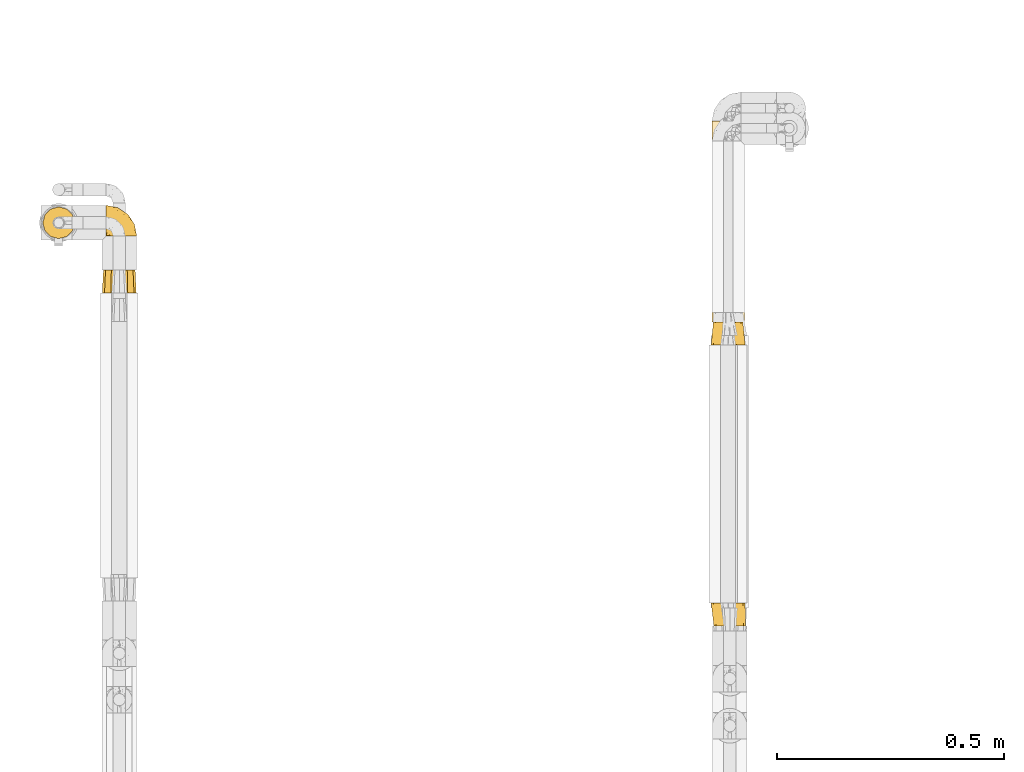
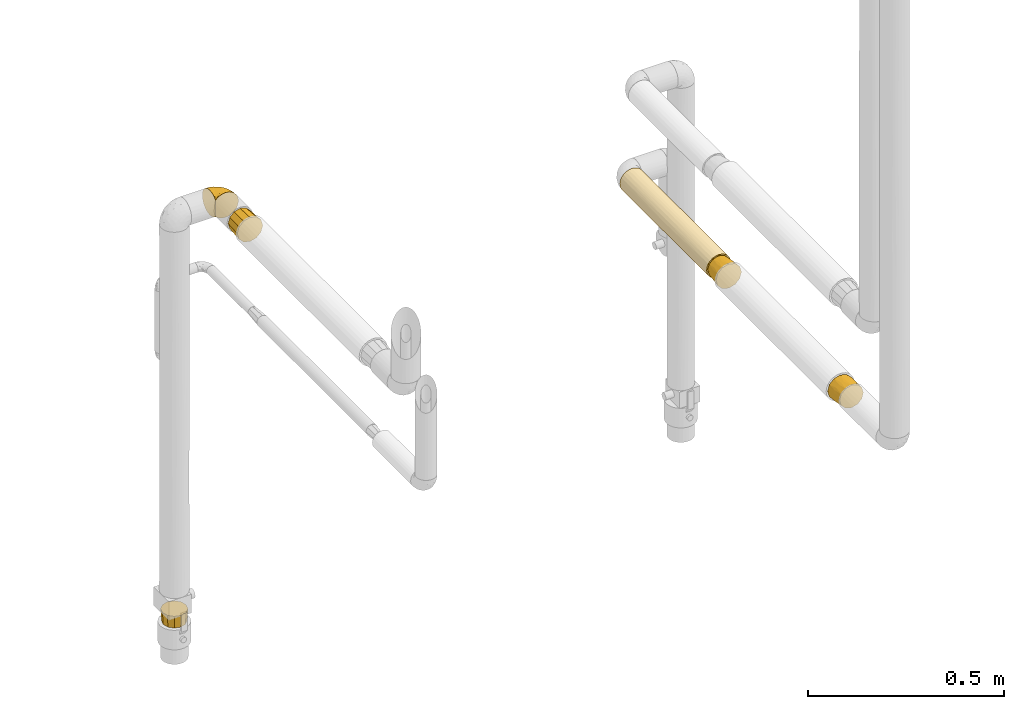
# One storey, part 63 of 827: 6 coverings.
"""IFC2X3 building model written with IfcOpenShell, lengths in millimetres."""

from ifc_helpers import new_model, entity, si_unit, converted_unit, derived_unit, direction, frame, origin, place, context, subcontext, project, spatial, faceted_brep, element, save


model = new_model("IFC2X3")

# Units and contexts
model_context = context("Model", 3, precision=0.01, world=origin(), true_north=direction((6.12303176911189e-17, 1.0)))
body_context = subcontext(model_context, "Body", "Model", "MODEL_VIEW")
ifc_project = project(units=[si_unit("LENGTHUNIT", "METRE", prefix="MILLI"), si_unit("AREAUNIT", "SQUARE_METRE"), si_unit("VOLUMEUNIT", "CUBIC_METRE"), converted_unit("PLANEANGLEUNIT", "DEGREE", entity("IfcRatioMeasure", 0.0174532925199433), si_unit("PLANEANGLEUNIT", "RADIAN"), dimensions=[0, 0, 0, 0, 0, 0, 0]), si_unit("MASSUNIT", "GRAM", prefix="KILO"), derived_unit("MASSDENSITYUNIT", [(si_unit("MASSUNIT", "GRAM", prefix="KILO"), 1), (si_unit("LENGTHUNIT", "METRE"), -3)]), derived_unit("MOMENTOFINERTIAUNIT", [(si_unit("LENGTHUNIT", "METRE"), 4)]), si_unit("TIMEUNIT", "SECOND"), si_unit("FREQUENCYUNIT", "HERTZ"), si_unit("THERMODYNAMICTEMPERATUREUNIT", "DEGREE_CELSIUS"), derived_unit("THERMALTRANSMITTANCEUNIT", [(si_unit("MASSUNIT", "GRAM", prefix="KILO"), 1), (si_unit("THERMODYNAMICTEMPERATUREUNIT", "KELVIN"), -1), (si_unit("TIMEUNIT", "SECOND"), -3)]), derived_unit("VOLUMETRICFLOWRATEUNIT", [(si_unit("LENGTHUNIT", "METRE"), 3), (si_unit("TIMEUNIT", "SECOND"), -1)]), derived_unit("MASSFLOWRATEUNIT", [(si_unit("MASSUNIT", "GRAM", prefix="KILO"), 1), (si_unit("TIMEUNIT", "SECOND"), -1)]), derived_unit("ROTATIONALFREQUENCYUNIT", [(si_unit("TIMEUNIT", "SECOND"), -1)]), si_unit("ELECTRICCURRENTUNIT", "AMPERE"), si_unit("ELECTRICVOLTAGEUNIT", "VOLT"), si_unit("POWERUNIT", "WATT"), si_unit("FORCEUNIT", "NEWTON", prefix="KILO"), si_unit("ILLUMINANCEUNIT", "LUX"), si_unit("LUMINOUSFLUXUNIT", "LUMEN"), si_unit("LUMINOUSINTENSITYUNIT", "CANDELA"), derived_unit("USERDEFINED", [(si_unit("MASSUNIT", "GRAM", prefix="KILO"), -1), (si_unit("LENGTHUNIT", "METRE"), -2), (si_unit("TIMEUNIT", "SECOND"), 3), (si_unit("LUMINOUSFLUXUNIT", "LUMEN"), 1)]), derived_unit("LINEARVELOCITYUNIT", [(si_unit("LENGTHUNIT", "METRE"), 1), (si_unit("TIMEUNIT", "SECOND"), -1)]), si_unit("PRESSUREUNIT", "PASCAL"), derived_unit("USERDEFINED", [(si_unit("LENGTHUNIT", "METRE"), -2), (si_unit("MASSUNIT", "GRAM", prefix="KILO"), 1), (si_unit("TIMEUNIT", "SECOND"), -2)]), derived_unit("LINEARFORCEUNIT", [(si_unit("MASSUNIT", "GRAM", prefix="KILO"), 1), (si_unit("LENGTHUNIT", "METRE"), 1), (si_unit("TIMEUNIT", "SECOND"), -2), (si_unit("LENGTHUNIT", "METRE"), -1)]), derived_unit("PLANARFORCEUNIT", [(si_unit("MASSUNIT", "GRAM", prefix="KILO"), 1), (si_unit("LENGTHUNIT", "METRE"), 1), (si_unit("TIMEUNIT", "SECOND"), -2), (si_unit("LENGTHUNIT", "METRE"), -2)])], contexts=[model_context])

# Site, building, storey
site_placement = place(None, origin())
site = spatial("IfcSite", under=ifc_project, at=site_placement, CompositionType="ELEMENT")
building_placement = place(site_placement, origin())
building = spatial("IfcBuilding", under=site, at=building_placement, CompositionType="ELEMENT")
storey_placement = place(building_placement, frame((0.0, 0.0, 28200.0)))
storey = spatial("IfcBuildingStorey", under=building, at=storey_placement, Name="08", CompositionType="ELEMENT", Elevation=28200.0)

# Coverings
covering_1_placement = place(storey_placement, frame((13237.87, 11951.32, 962.76)))
element("IfcCovering", 1, at=covering_1_placement, inside=storey, Name=":ADSK_", ObjectType=":ADSK_", PredefinedType="INSULATION", context=body_context, shape_type="Brep", body=[
    faceted_brep([(12.04, 443.25, 62.45), (19.42, 443.25, 68.12), (28.02, 443.25, 71.68), (37.25, 443.25, 72.9), (45.24, 443.25, 71.99), (52.81, 443.25, 69.32), (59.6, 443.25, 65.02), (65.25, 443.25, 59.31), (65.25, 443.25, 15.18), (59.6, 443.25, 9.47), (52.81, 443.25, 5.17), (45.24, 443.25, 2.5), (37.25, 443.25, 1.6), (28.02, 443.25, 2.81), (19.42, 443.25, 6.37), (12.04, 443.25, 12.04), (6.37, 443.25, 19.42), (2.81, 443.25, 28.02), (1.6, 443.25, 37.25), (2.81, 443.25, 46.47), (6.37, 443.25, 55.07), (28.02, 0.0, 71.68), (19.42, 0.0, 68.12), (12.04, 0.0, 62.45), (6.37, 0.0, 55.07), (2.81, 0.0, 46.47), (1.6, 0.0, 37.25), (2.81, 0.0, 28.02), (6.37, 0.0, 19.42), (12.04, 0.0, 12.04), (19.42, 0.0, 6.37), (28.02, 0.0, 2.81), (37.25, 0.0, 1.6), (46.47, 0.0, 2.81), (55.07, 0.0, 6.37), (62.45, 0.0, 12.04), (68.12, 0.0, 19.42), (71.68, 0.0, 28.02), (72.9, 0.0, 37.25), (71.68, 0.0, 46.47), (68.12, 0.0, 55.07), (62.45, 0.0, 62.45), (55.07, 0.0, 68.12), (46.47, 0.0, 71.68), (37.25, 0.0, 72.9), (37.25, 234.77, 1.6), (49.1, 229.71, 3.62), (72.11, 209.53, 29.82), (69.79, 214.91, 22.7), (72.9, 227.12, 37.25), (72.4, 436.09, 31.32), (66.71, 267.31, 17.18), (62.58, 236.76, 12.17), (72.9, 435.6, 37.25), (68.52, 439.97, 20.14), (70.93, 437.57, 25.57), (56.32, 242.07, 7.13), (30.26, 251.29, 2.29), (23.6, 221.62, 4.31), (2.27, 250.14, 30.33), (4.31, 221.62, 23.6), (15.54, 221.62, 8.96), (8.96, 221.62, 15.54), (1.6, 208.48, 37.25), (1.6, 234.77, 37.25), (2.29, 251.29, 44.23), (4.31, 221.62, 50.89), (30.33, 250.14, 72.22), (23.6, 221.62, 70.18), (8.96, 221.62, 58.95), (15.54, 221.62, 65.53), (37.25, 208.48, 72.9), (37.25, 234.77, 72.9), (49.1, 229.71, 70.87), (56.32, 242.07, 67.36), (66.6, 174.14, 57.47), (69.79, 214.91, 51.79), (68.52, 439.97, 54.35), (62.58, 236.76, 62.32), (72.11, 224.77, 44.68), (70.93, 437.57, 48.92), (72.4, 436.09, 43.17)], [[[0, 1, 2, 3, 4, 5, 6, 7, 8, 9, 10, 11, 12, 13, 14, 15, 16, 17, 18, 19, 20]], [[21, 22, 23, 24, 25, 26, 27, 28, 29, 30, 31, 32, 33, 34, 35, 36, 37, 38, 39, 40, 41, 42, 43, 44]], [[45, 46, 33]], [[47, 37, 48]], [[47, 38, 37]], [[49, 47, 50]], [[32, 45, 33]], [[51, 35, 52]], [[37, 36, 48]], [[46, 11, 10]], [[50, 53, 49]], [[48, 51, 54]], [[48, 54, 55]], [[55, 50, 47]], [[35, 51, 36]], [[51, 52, 8]], [[46, 56, 34]], [[34, 33, 46]], [[54, 51, 8]], [[36, 51, 48]], [[45, 12, 11]], [[9, 56, 10]], [[10, 56, 46]], [[47, 48, 55]], [[9, 52, 56]], [[45, 11, 46]], [[56, 52, 35]], [[38, 47, 49]], [[52, 9, 8]], [[56, 35, 34]], [[57, 31, 58]], [[27, 59, 60]], [[57, 12, 45, 32]], [[58, 31, 30]], [[57, 32, 31]], [[13, 58, 14]], [[58, 13, 57]], [[61, 15, 14]], [[61, 58, 30]], [[62, 61, 29]], [[59, 26, 63, 64, 18]], [[60, 28, 27]], [[59, 17, 60]], [[18, 17, 59]], [[62, 16, 15]], [[60, 62, 28]], [[26, 59, 27]], [[60, 16, 62]], [[61, 62, 15]], [[29, 61, 30]], [[16, 60, 17]], [[28, 62, 29]], [[12, 57, 13]], [[58, 61, 14]], [[65, 25, 66]], [[21, 67, 68]], [[65, 18, 64, 63, 26]], [[66, 25, 24]], [[65, 26, 25]], [[19, 66, 20]], [[66, 19, 65]], [[69, 0, 20]], [[69, 66, 24]], [[70, 69, 23]], [[67, 44, 71, 72, 3]], [[68, 22, 21]], [[67, 2, 68]], [[3, 2, 67]], [[70, 1, 0]], [[68, 70, 22]], [[44, 67, 21]], [[68, 1, 70]], [[69, 70, 0]], [[23, 69, 24]], [[1, 68, 2]], [[22, 70, 23]], [[18, 65, 19]], [[66, 69, 20]], [[72, 73, 4]], [[42, 41, 74]], [[75, 76, 77]], [[41, 75, 78]], [[41, 78, 74]], [[49, 79, 38]], [[43, 72, 71, 44]], [[42, 73, 43]], [[73, 5, 4]], [[5, 73, 74]], [[4, 3, 72]], [[78, 7, 6]], [[77, 76, 80]], [[80, 79, 81]], [[42, 74, 73]], [[53, 81, 49]], [[6, 74, 78]], [[49, 81, 79]], [[72, 43, 73]], [[7, 78, 75]], [[40, 39, 76]], [[38, 79, 39]], [[77, 7, 75]], [[80, 76, 79]], [[41, 40, 75]], [[75, 40, 76]], [[39, 79, 76]], [[5, 74, 6]], [[7, 77, 80, 81, 53, 50, 55, 54, 8]]]),
])
covering_2_placement = place(storey_placement, frame((13236.02, 11900.32, 960.9)))
element("IfcCovering", 2, at=covering_2_placement, inside=storey, Name=":ADSK_", ObjectType=":ADSK_", PredefinedType="INSULATION", context=body_context, shape_type="Brep", body=[
    faceted_brep([(13.48, 0.0, 64.71), (6.62, 0.0, 57.85), (4.11, 0.0, 48.47), (1.6, 0.0, 39.1), (4.11, 0.0, 29.72), (6.62, 0.0, 20.35), (13.48, 0.0, 13.48), (20.35, 0.0, 6.62), (29.72, 0.0, 4.11), (39.1, 0.0, 1.6), (48.47, 0.0, 4.11), (57.85, 0.0, 6.62), (64.71, 0.0, 13.48), (71.57, 0.0, 20.35), (74.08, 0.0, 29.72), (76.6, 0.0, 39.1), (74.08, 0.0, 48.47), (71.57, 0.0, 57.85), (64.71, 0.0, 64.71), (57.85, 0.0, 71.57), (48.47, 0.0, 74.08), (39.1, 0.0, 76.6), (29.72, 0.0, 74.08), (20.35, 0.0, 71.57), (10.95, 51.0, 55.35), (16.9, 51.0, 61.29), (22.85, 51.0, 67.24), (32.86, 51.0, 69.93), (39.1, 51.0, 71.6), (47.22, 51.0, 69.42), (55.35, 51.0, 67.24), (61.29, 51.0, 61.29), (67.24, 51.0, 55.35), (69.92, 51.0, 45.33), (71.6, 51.0, 39.1), (69.42, 51.0, 30.97), (67.24, 51.0, 22.85), (61.29, 51.0, 16.9), (55.35, 51.0, 10.95), (45.33, 51.0, 8.27), (39.1, 51.0, 6.6), (30.97, 51.0, 8.77), (22.85, 51.0, 10.95), (16.9, 51.0, 16.9), (10.95, 51.0, 22.85), (8.27, 51.0, 32.86), (6.6, 51.0, 39.1), (8.77, 51.0, 47.22), (6.76, 25.5, 25.7), (4.66, 24.36, 32.24), (10.24, 25.5, 19.28), (30.4, 25.5, 5.19), (17.79, 25.5, 11.33), (24.02, 25.5, 7.51), (4.01, 24.59, 39.1), (39.1, 24.59, 4.01), (52.49, 25.5, 6.76), (45.95, 24.36, 4.66), (58.91, 25.5, 10.24), (73.0, 25.5, 30.4), (66.86, 25.5, 17.79), (70.68, 25.5, 24.02), (74.18, 24.59, 39.1), (71.43, 25.5, 52.49), (73.53, 24.36, 45.95), (67.95, 25.5, 58.91), (47.79, 25.5, 73.0), (60.4, 25.5, 66.86), (54.17, 25.5, 70.68), (39.1, 24.59, 74.19), (25.7, 25.5, 71.43), (32.24, 24.36, 73.53), (19.28, 25.5, 67.95), (5.19, 25.5, 47.79), (11.33, 25.5, 60.4), (7.51, 25.5, 54.17)], [[[0, 1, 2, 3, 4, 5, 6, 7, 8, 9, 10, 11, 12, 13, 14, 15, 16, 17, 18, 19, 20, 21, 22, 23]], [[24, 25, 26, 27, 28, 29, 30, 31, 32, 33, 34, 35, 36, 37, 38, 39, 40, 41, 42, 43, 44, 45, 46, 47]], [[45, 48, 49]], [[49, 46, 45]], [[48, 45, 44]], [[5, 4, 48]], [[50, 5, 48]], [[48, 4, 49]], [[9, 8, 51]], [[52, 50, 43]], [[50, 48, 44]], [[7, 52, 53]], [[53, 52, 42]], [[43, 42, 52]], [[50, 44, 43]], [[54, 46, 49, 3]], [[52, 6, 50]], [[6, 5, 50]], [[6, 52, 7]], [[51, 8, 53]], [[53, 41, 51]], [[53, 42, 41]], [[3, 49, 4]], [[8, 7, 53]], [[40, 55, 9, 51]], [[40, 51, 41]], [[39, 56, 57]], [[57, 40, 39]], [[56, 39, 38]], [[11, 10, 56]], [[58, 11, 56]], [[56, 10, 57]], [[15, 14, 59]], [[60, 58, 37]], [[58, 56, 38]], [[13, 60, 61]], [[61, 60, 36]], [[37, 36, 60]], [[58, 38, 37]], [[55, 40, 57, 9]], [[60, 12, 58]], [[12, 11, 58]], [[12, 60, 13]], [[59, 14, 61]], [[61, 35, 59]], [[61, 36, 35]], [[9, 57, 10]], [[14, 13, 61]], [[34, 62, 15, 59]], [[34, 59, 35]], [[33, 63, 64]], [[64, 34, 33]], [[63, 33, 32]], [[17, 16, 63]], [[65, 17, 63]], [[63, 16, 64]], [[21, 20, 66]], [[67, 65, 31]], [[65, 63, 32]], [[19, 67, 68]], [[68, 67, 30]], [[31, 30, 67]], [[65, 32, 31]], [[62, 34, 64, 15]], [[67, 18, 65]], [[18, 17, 65]], [[18, 67, 19]], [[66, 20, 68]], [[68, 29, 66]], [[68, 30, 29]], [[15, 64, 16]], [[20, 19, 68]], [[28, 69, 21, 66]], [[28, 66, 29]], [[27, 70, 71]], [[71, 28, 27]], [[70, 27, 26]], [[23, 22, 70]], [[72, 23, 70]], [[70, 22, 71]], [[3, 2, 73]], [[74, 72, 25]], [[72, 70, 26]], [[1, 74, 75]], [[75, 74, 24]], [[25, 24, 74]], [[72, 26, 25]], [[69, 28, 71, 21]], [[74, 0, 72]], [[0, 23, 72]], [[0, 74, 1]], [[73, 2, 75]], [[75, 47, 73]], [[75, 24, 47]], [[21, 71, 22]], [[2, 1, 75]], [[46, 54, 3, 73]], [[46, 73, 47]]]),
])
covering_3_placement = place(storey_placement, frame((13236.02, 11280.38, 960.91)))
element("IfcCovering", 3, at=covering_3_placement, inside=storey, Name=":ADSK_", ObjectType=":ADSK_", PredefinedType="INSULATION", context=body_context, shape_type="Brep", body=[
    faceted_brep([(10.12, 0.0, 47.85), (7.78, 0.0, 39.1), (10.12, 0.0, 30.35), (12.47, 0.0, 21.6), (18.87, 0.0, 15.19), (25.28, 0.0, 8.78), (34.03, 0.0, 6.44), (42.78, 0.0, 4.1), (51.53, 0.0, 6.44), (60.28, 0.0, 8.78), (66.68, 0.0, 15.19), (73.09, 0.0, 21.6), (75.43, 0.0, 30.35), (77.78, 0.0, 39.1), (75.43, 0.0, 47.85), (73.09, 0.0, 56.6), (66.68, 0.0, 63.0), (60.28, 0.0, 69.41), (51.53, 0.0, 71.75), (42.78, 0.0, 74.1), (34.03, 0.0, 71.75), (25.28, 0.0, 69.41), (18.87, 0.0, 63.0), (12.47, 0.0, 56.6), (57.85, 51.0, 71.57), (64.71, 51.0, 64.71), (71.57, 51.0, 57.85), (74.63, 51.0, 46.43), (76.6, 51.0, 39.1), (74.08, 51.0, 29.72), (71.57, 51.0, 20.35), (64.71, 51.0, 13.48), (57.85, 51.0, 6.62), (46.43, 51.0, 3.56), (39.1, 51.0, 1.6), (29.72, 51.0, 4.11), (20.35, 51.0, 6.62), (13.48, 51.0, 13.48), (6.62, 51.0, 20.35), (3.56, 51.0, 31.78), (1.6, 51.0, 39.1), (4.11, 51.0, 48.47), (6.62, 51.0, 57.85), (13.48, 51.0, 64.71), (20.35, 51.0, 71.57), (31.78, 51.0, 74.64), (39.1, 51.0, 76.6), (48.47, 51.0, 74.08), (7.45, 25.5, 25.22), (5.52, 24.36, 32.03), (11.05, 25.5, 18.57), (31.93, 25.5, 3.98), (18.87, 25.5, 10.34), (25.32, 25.5, 6.38), (4.85, 24.14, 39.1), (41.03, 24.14, 2.91), (54.81, 25.5, 5.6), (48.08, 24.36, 3.6), (61.46, 25.5, 9.21), (76.05, 25.5, 30.09), (69.69, 25.5, 17.03), (73.65, 25.5, 23.48), (77.22, 24.07, 39.1), (74.43, 25.5, 52.97), (76.52, 24.36, 46.16), (70.82, 25.5, 59.62), (49.95, 25.5, 74.21), (63.0, 25.5, 67.85), (56.55, 25.5, 71.81), (41.04, 24.07, 75.28), (27.06, 25.5, 72.59), (33.95, 24.36, 74.59), (20.41, 25.5, 68.98), (5.82, 25.5, 48.11), (12.18, 25.5, 61.16), (8.22, 25.5, 54.71)], [[[0, 1, 2, 3, 4, 5, 6, 7, 8, 9, 10, 11, 12, 13, 14, 15, 16, 17, 18, 19, 20, 21, 22, 23]], [[24, 25, 26, 27, 28, 29, 30, 31, 32, 33, 34, 35, 36, 37, 38, 39, 40, 41, 42, 43, 44, 45, 46, 47]], [[39, 48, 49]], [[49, 40, 39]], [[48, 39, 38]], [[3, 2, 48]], [[50, 3, 48]], [[48, 2, 49]], [[7, 6, 51]], [[52, 50, 37]], [[50, 48, 38]], [[5, 52, 53]], [[53, 52, 36]], [[37, 36, 52]], [[50, 38, 37]], [[54, 40, 49, 1]], [[52, 4, 50]], [[4, 3, 50]], [[4, 52, 5]], [[51, 6, 53]], [[53, 35, 51]], [[53, 36, 35]], [[1, 49, 2]], [[6, 5, 53]], [[34, 55, 7, 51]], [[34, 51, 35]], [[33, 56, 57]], [[57, 34, 33]], [[56, 33, 32]], [[9, 8, 56]], [[58, 9, 56]], [[56, 8, 57]], [[13, 12, 59]], [[60, 58, 31]], [[58, 56, 32]], [[11, 60, 61]], [[61, 60, 30]], [[31, 30, 60]], [[58, 32, 31]], [[55, 34, 57, 7]], [[60, 10, 58]], [[10, 9, 58]], [[10, 60, 11]], [[59, 12, 61]], [[61, 29, 59]], [[61, 30, 29]], [[7, 57, 8]], [[12, 11, 61]], [[28, 62, 13, 59]], [[28, 59, 29]], [[27, 63, 64]], [[64, 28, 27]], [[63, 27, 26]], [[15, 14, 63]], [[65, 15, 63]], [[63, 14, 64]], [[19, 18, 66]], [[67, 65, 25]], [[65, 63, 26]], [[17, 67, 68]], [[68, 67, 24]], [[25, 24, 67]], [[65, 26, 25]], [[62, 28, 64, 13]], [[67, 16, 65]], [[16, 15, 65]], [[16, 67, 17]], [[66, 18, 68]], [[68, 47, 66]], [[68, 24, 47]], [[13, 64, 14]], [[18, 17, 68]], [[46, 69, 19, 66]], [[46, 66, 47]], [[45, 70, 71]], [[71, 46, 45]], [[70, 45, 44]], [[21, 20, 70]], [[72, 21, 70]], [[70, 20, 71]], [[1, 0, 73]], [[74, 72, 43]], [[72, 70, 44]], [[23, 74, 75]], [[75, 74, 42]], [[43, 42, 74]], [[72, 44, 43]], [[69, 46, 71, 19]], [[74, 22, 72]], [[22, 21, 72]], [[22, 74, 23]], [[73, 0, 75]], [[75, 41, 73]], [[75, 42, 41]], [[19, 71, 20]], [[0, 23, 75]], [[40, 54, 1, 73]], [[40, 73, 41]]]),
])
covering_4_placement = place(storey_placement, frame((11901.21, 12139.36, 1505.7)))
element("IfcCovering", 4, at=covering_4_placement, inside=storey, Name=":ADSK_", ObjectType=":ADSK_", PredefinedType="INSULATION", context=body_context, shape_type="Brep", body=[
    faceted_brep([(1.6, 47.38, 74.69), (1.6, 54.67, 70.1), (1.6, 60.76, 64.01), (1.6, 65.34, 56.72), (1.6, 68.18, 48.6), (1.6, 69.15, 40.05), (1.6, 68.18, 31.49), (1.6, 65.33, 23.36), (1.6, 60.75, 16.07), (1.6, 54.66, 9.98), (1.6, 47.37, 5.4), (1.6, 39.25, 2.56), (1.6, 30.7, 1.6), (1.6, 22.59, 2.46), (1.6, 14.86, 5.01), (1.6, 7.84, 9.13), (1.6, 1.85, 14.62), (1.6, 1.85, 16.82), (1.6, 1.85, 18.56), (1.6, 1.85, 20.52), (1.6, 1.85, 22.49), (1.6, 1.85, 24.46), (1.6, 1.85, 26.42), (1.6, 1.85, 28.39), (1.6, 1.85, 30.36), (1.6, 1.85, 32.55), (1.6, 1.85, 34.75), (1.6, 1.85, 36.94), (1.6, 1.85, 39.13), (1.6, 1.85, 41.33), (1.6, 1.85, 43.52), (1.6, 1.85, 45.72), (1.6, 1.85, 47.91), (1.6, 1.85, 50.11), (1.6, 1.85, 52.3), (1.6, 1.85, 54.5), (1.6, 1.85, 56.69), (1.6, 1.85, 58.88), (1.6, 1.85, 61.08), (1.6, 1.85, 63.27), (1.6, 1.85, 65.47), (1.6, 7.85, 70.97), (1.6, 14.88, 75.09), (1.6, 22.61, 77.64), (1.6, 30.7, 78.5), (1.6, 39.26, 77.53), (1.85, 1.6, 14.62), (7.85, 1.6, 9.12), (14.87, 1.6, 5.0), (22.6, 1.6, 2.46), (30.7, 1.6, 1.6), (40.65, 1.6, 2.91), (49.92, 1.6, 6.75), (57.88, 1.6, 12.86), (63.99, 1.6, 20.82), (67.84, 1.6, 30.09), (69.15, 1.6, 40.04), (67.84, 1.6, 50.0), (64.0, 1.6, 59.27), (57.88, 1.6, 67.23), (49.92, 1.6, 73.34), (40.65, 1.6, 77.18), (30.7, 1.6, 78.5), (22.6, 1.6, 77.63), (14.87, 1.6, 75.09), (7.85, 1.6, 70.97), (1.85, 1.6, 65.47), (1.85, 1.6, 63.27), (1.85, 1.6, 62.29), (1.85, 1.6, 60.7), (1.85, 1.6, 59.11), (1.85, 1.6, 57.52), (1.85, 1.6, 55.93), (1.85, 1.6, 54.35), (1.85, 1.6, 52.76), (1.85, 1.6, 51.17), (1.85, 1.6, 49.58), (1.85, 1.6, 47.99), (1.85, 1.6, 46.4), (1.85, 1.6, 44.81), (1.85, 1.6, 43.22), (1.85, 1.6, 41.63), (1.85, 1.6, 40.05), (1.85, 1.6, 38.46), (1.85, 1.6, 36.87), (1.85, 1.6, 35.28), (1.85, 1.6, 33.69), (1.85, 1.6, 32.1), (1.85, 1.6, 30.51), (1.85, 1.6, 28.92), (1.85, 1.6, 27.34), (1.85, 1.6, 25.37), (1.85, 1.6, 23.4), (1.85, 1.6, 21.21), (1.85, 1.6, 19.01), (1.85, 1.6, 16.82), (1.77, 1.78, 42.32), (1.78, 1.77, 44.02), (1.77, 1.78, 47.13), (1.78, 1.77, 48.74), (1.76, 1.79, 23.57), (1.77, 1.78, 25.13), (1.79, 1.76, 61.34), (1.78, 1.77, 22.02), (1.78, 1.77, 29.72), (1.79, 1.76, 56.73), (1.78, 1.77, 55.14), (1.78, 1.77, 37.66), (1.74, 1.8, 64.12), (1.78, 1.76, 28.13), (1.78, 1.77, 26.62), (1.77, 1.78, 31.46), (1.78, 1.77, 16.16), (1.78, 1.77, 39.16), (1.78, 1.76, 50.37), (1.77, 1.77, 17.69), (1.77, 1.78, 19.17), (1.78, 1.77, 62.78), (1.78, 1.77, 58.35), (1.78, 1.77, 45.53), (1.77, 1.78, 59.91), (1.78, 1.77, 65.47), (1.72, 1.8, 65.47), (1.66, 1.82, 65.47), (1.77, 1.77, 14.62), (1.8, 1.72, 14.62), (1.82, 1.66, 14.62), (1.79, 1.76, 20.59), (1.78, 1.77, 32.99), (1.79, 1.76, 34.48), (1.78, 1.77, 51.91), (1.82, 1.66, 65.47), (1.8, 1.72, 65.47), (1.77, 1.78, 53.48), (1.66, 1.82, 14.62), (1.72, 1.8, 14.62), (1.78, 1.77, 40.77), (1.77, 1.78, 35.97), (9.41, 3.72, 7.84), (17.65, 7.41, 3.53), (7.41, 6.13, 8.32), (21.47, 21.47, 1.6), (15.21, 19.34, 2.19), (16.15, 26.8, 1.6), (28.75, 8.87, 1.6), (13.67, 9.2, 4.57), (12.79, 12.79, 3.96), (19.18, 14.62, 2.28), (29.16, 7.34, 1.6), (9.04, 5.33, 7.69), (7.41, 17.64, 3.53), (5.74, 7.7, 8.32), (3.72, 9.41, 7.84), (8.87, 28.75, 1.6), (26.8, 16.15, 1.6), (9.53, 14.14, 4.34), (7.34, 29.16, 1.6), (37.63, 57.02, 29.63), (17.92, 64.92, 27.34), (27.45, 64.0, 40.05), (37.01, 11.92, 2.39), (34.22, 19.16, 2.43), (45.87, 28.65, 9.07), (56.57, 24.62, 16.64), (52.31, 15.19, 9.54), (42.07, 18.36, 4.52), (44.74, 9.2, 4.52), (21.49, 46.98, 7.49), (11.02, 50.24, 7.49), (15.64, 56.1, 12.85), (26.02, 28.97, 2.35), (36.6, 54.46, 22.66), (65.49, 21.34, 32.9), (63.99, 18.4, 25.33), (15.2, 66.44, 40.05), (60.27, 12.07, 16.64), (45.25, 45.49, 19.99), (35.21, 50.57, 16.37), (22.52, 36.04, 3.26), (12.03, 42.07, 3.75), (13.32, 62.12, 19.58), (35.9, 37.37, 7.5), (33.87, 29.39, 4.04), (25.73, 53.59, 13.94), (26.34, 58.06, 19.58), (46.78, 49.27, 28.21), (59.54, 29.63, 24.75), (60.18, 33.21, 31.42), (53.93, 40.1, 26.2), (53.36, 44.08, 33.36), (49.36, 49.36, 40.04), (38.4, 56.68, 40.05), (66.44, 15.2, 40.04), (50.09, 35.57, 16.14), (41.08, 41.7, 12.85), (31.14, 46.4, 10.47), (28.19, 41.41, 6.49), (64.0, 27.45, 40.04), (56.68, 38.4, 40.04), (43.9, 12.99, 75.57), (65.46, 21.33, 47.37), (52.22, 42.89, 52.91), (37.61, 57.04, 50.46), (15.64, 56.11, 67.23), (13.31, 62.13, 60.5), (50.02, 21.89, 70.55), (59.28, 16.62, 63.45), (53.05, 32.9, 62.61), (21.48, 46.99, 72.6), (11.02, 50.25, 72.6), (12.03, 42.08, 76.34), (41.02, 49.91, 59.34), (35.4, 15.6, 77.76), (26.8, 16.15, 78.5), (28.75, 8.87, 78.5), (7.34, 29.16, 78.5), (65.81, 13.16, 53.15), (53.28, 10.83, 70.55), (59.8, 33.8, 48.88), (61.83, 25.02, 54.76), (17.91, 64.92, 52.74), (41.4, 32.83, 71.93), (40.48, 20.56, 75.79), (26.34, 58.07, 60.5), (31.68, 21.46, 77.86), (27.68, 28.1, 77.64), (16.15, 26.8, 78.5), (21.47, 21.47, 78.5), (28.05, 51.29, 67.23), (22.54, 36.04, 76.82), (8.87, 28.75, 78.5), (37.3, 8.45, 77.8), (41.07, 41.73, 67.23), (32.24, 39.27, 73.2), (47.4, 33.56, 67.66), (35.77, 27.29, 75.99), (17.65, 7.41, 76.57), (11.06, 3.51, 73.22), (8.56, 4.68, 71.93), (6.63, 5.52, 71.07), (12.77, 8.75, 75.09), (12.79, 12.79, 76.13), (7.42, 17.65, 76.57), (18.97, 13.9, 77.69), (3.73, 9.42, 72.26), (5.77, 7.68, 71.77), (15.21, 19.33, 77.9), (9.52, 14.13, 75.75)], [[[0, 1, 2, 3, 4, 5, 6, 7, 8, 9, 10, 11, 12, 13, 14, 15, 16, 17, 18, 19, 20, 21, 22, 23, 24, 25, 26, 27, 28, 29, 30, 31, 32, 33, 34, 35, 36, 37, 38, 39, 40, 41, 42, 43, 44, 45]], [[46, 47, 48, 49, 50, 51, 52, 53, 54, 55, 56, 57, 58, 59, 60, 61, 62, 63, 64, 65, 66, 67, 68, 69, 70, 71, 72, 73, 74, 75, 76, 77, 78, 79, 80, 81, 82, 83, 84, 85, 86, 87, 88, 89, 90, 91, 92, 93, 94, 95]], [[96, 97, 30]], [[98, 77, 99]], [[100, 101, 21]], [[69, 68, 102]], [[20, 19, 103]], [[24, 23, 104]], [[20, 103, 100]], [[72, 105, 106]], [[84, 83, 107]], [[89, 88, 104]], [[108, 67, 66]], [[109, 110, 90]], [[111, 25, 24]], [[112, 17, 16]], [[82, 113, 83]], [[109, 23, 22]], [[114, 76, 75]], [[105, 36, 106]], [[104, 111, 24]], [[18, 115, 116]], [[97, 96, 80]], [[67, 108, 117]], [[105, 71, 118]], [[31, 97, 119]], [[102, 120, 69]], [[108, 121, 122, 123, 40]], [[112, 95, 115]], [[17, 115, 18]], [[94, 116, 115]], [[117, 68, 67]], [[38, 117, 39]], [[112, 124, 125, 126, 46]], [[17, 112, 115]], [[70, 120, 118]], [[39, 117, 108]], [[120, 38, 37]], [[120, 37, 118]], [[120, 70, 69]], [[116, 94, 127]], [[128, 86, 129]], [[117, 38, 102]], [[74, 130, 75]], [[99, 33, 32]], [[115, 95, 94]], [[39, 108, 40]], [[108, 66, 131, 132, 121]], [[105, 72, 71]], [[118, 37, 36]], [[71, 70, 118]], [[35, 106, 36]], [[36, 105, 118]], [[35, 133, 106]], [[74, 73, 133]], [[106, 133, 73]], [[99, 114, 33]], [[133, 35, 34]], [[73, 72, 106]], [[95, 112, 46]], [[112, 16, 134, 135, 124]], [[130, 114, 75]], [[99, 76, 114]], [[114, 130, 33]], [[34, 33, 130]], [[78, 77, 98]], [[98, 119, 78]], [[130, 133, 34]], [[133, 130, 74]], [[79, 97, 80]], [[98, 99, 32]], [[98, 32, 31]], [[77, 76, 99]], [[97, 79, 119]], [[136, 96, 29]], [[30, 97, 31]], [[136, 29, 28]], [[81, 80, 96]], [[29, 96, 30]], [[31, 119, 98]], [[119, 79, 78]], [[96, 136, 81]], [[82, 81, 136]], [[113, 107, 83]], [[84, 107, 137]], [[107, 27, 137]], [[113, 28, 107]], [[27, 107, 28]], [[85, 84, 137]], [[137, 27, 26]], [[113, 136, 28]], [[136, 113, 82]], [[109, 89, 104]], [[86, 85, 129]], [[89, 109, 90]], [[111, 87, 128]], [[26, 129, 137]], [[88, 111, 104]], [[25, 111, 128]], [[22, 110, 109]], [[23, 109, 104]], [[110, 91, 90]], [[100, 92, 101]], [[110, 22, 101]], [[91, 110, 101]], [[116, 19, 18]], [[111, 88, 87]], [[127, 103, 19]], [[25, 128, 26]], [[86, 128, 87]], [[128, 129, 26]], [[137, 129, 85]], [[120, 102, 38]], [[117, 102, 68]], [[91, 101, 92]], [[21, 101, 22]], [[93, 92, 103]], [[100, 21, 20]], [[100, 103, 92]], [[127, 93, 103]], [[93, 127, 94]], [[116, 127, 19]], [[126, 138, 47]], [[48, 138, 139]], [[140, 125, 124]], [[141, 142, 143]], [[144, 49, 139]], [[145, 140, 146]], [[48, 139, 49]], [[139, 145, 147]], [[49, 144, 148, 50]], [[126, 125, 149]], [[14, 13, 150]], [[151, 146, 140]], [[149, 140, 145]], [[152, 151, 135]], [[152, 14, 150]], [[16, 15, 134]], [[13, 153, 150]], [[124, 151, 140]], [[141, 147, 142]], [[14, 152, 15]], [[15, 152, 134]], [[47, 46, 126]], [[139, 154, 144]], [[138, 48, 47]], [[125, 140, 149]], [[135, 134, 152]], [[146, 155, 142]], [[145, 146, 147]], [[149, 139, 138]], [[147, 141, 154]], [[147, 146, 142]], [[139, 147, 154]], [[139, 149, 145]], [[149, 138, 126]], [[155, 146, 151]], [[150, 143, 142]], [[152, 155, 151]], [[150, 142, 155]], [[13, 12, 156, 153]], [[153, 143, 150]], [[152, 150, 155]], [[151, 124, 135]], [[157, 158, 159]], [[160, 154, 161]], [[162, 163, 164]], [[165, 166, 160]], [[167, 168, 169]], [[141, 170, 161]], [[156, 12, 11]], [[158, 157, 171]], [[172, 55, 173]], [[158, 6, 174]], [[175, 54, 53]], [[52, 166, 164]], [[52, 164, 53]], [[54, 175, 173]], [[166, 52, 51]], [[176, 177, 171]], [[178, 143, 179]], [[156, 11, 179]], [[8, 7, 180]], [[169, 9, 8]], [[179, 143, 153, 156]], [[179, 11, 10]], [[168, 179, 10]], [[181, 162, 182]], [[179, 167, 178]], [[183, 184, 177]], [[183, 169, 184]], [[176, 171, 185]], [[172, 186, 187]], [[158, 7, 6]], [[159, 158, 174]], [[184, 180, 158]], [[54, 173, 55]], [[180, 169, 8]], [[188, 189, 187]], [[9, 168, 10]], [[186, 188, 187]], [[190, 157, 159, 191]], [[55, 172, 192]], [[176, 193, 194]], [[161, 170, 182]], [[51, 50, 148]], [[162, 164, 165]], [[175, 164, 163]], [[167, 195, 196]], [[178, 182, 170]], [[6, 5, 174]], [[158, 180, 7]], [[169, 180, 184]], [[169, 168, 9]], [[179, 168, 167]], [[182, 162, 165]], [[162, 194, 193]], [[161, 165, 160]], [[195, 181, 196]], [[192, 172, 197]], [[192, 56, 55]], [[189, 190, 198]], [[198, 197, 187]], [[172, 187, 197]], [[185, 189, 188]], [[198, 187, 189]], [[186, 172, 173]], [[173, 163, 186]], [[193, 186, 163]], [[176, 185, 188]], [[185, 157, 190]], [[188, 186, 193]], [[177, 176, 194]], [[188, 193, 176]], [[162, 193, 163]], [[195, 177, 194]], [[171, 177, 184]], [[181, 195, 194]], [[183, 167, 169]], [[162, 181, 194]], [[196, 182, 178]], [[158, 171, 184]], [[171, 157, 185]], [[177, 195, 183]], [[167, 183, 195]], [[182, 196, 181]], [[178, 170, 143]], [[178, 167, 196]], [[164, 175, 53]], [[173, 175, 163]], [[160, 51, 148]], [[164, 166, 165]], [[51, 160, 166]], [[160, 148, 144, 154]], [[141, 161, 154]], [[182, 165, 161]], [[190, 189, 185]], [[143, 170, 141]], [[60, 199, 61]], [[197, 200, 192]], [[201, 190, 202]], [[200, 57, 192]], [[203, 204, 2]], [[205, 206, 207]], [[208, 209, 210]], [[211, 207, 201]], [[212, 213, 214]], [[45, 215, 210]], [[216, 206, 58]], [[45, 44, 215]], [[59, 217, 60]], [[60, 217, 199]], [[0, 45, 210]], [[218, 201, 219]], [[202, 159, 220]], [[205, 221, 222]], [[223, 204, 203]], [[1, 203, 2]], [[57, 200, 216]], [[220, 3, 204]], [[220, 174, 4]], [[1, 0, 209]], [[212, 224, 213]], [[225, 226, 227]], [[228, 223, 203]], [[208, 210, 229]], [[210, 226, 229]], [[3, 220, 4]], [[58, 206, 59]], [[209, 203, 1]], [[202, 220, 223]], [[228, 203, 208]], [[202, 211, 201]], [[3, 2, 204]], [[202, 190, 191, 159]], [[210, 215, 230, 226]], [[199, 212, 231]], [[232, 233, 221]], [[233, 208, 229]], [[207, 206, 219]], [[217, 206, 205]], [[227, 224, 225]], [[233, 232, 228]], [[201, 207, 219]], [[234, 232, 221]], [[218, 219, 200]], [[202, 223, 211]], [[174, 220, 159]], [[174, 5, 4]], [[61, 231, 62]], [[220, 204, 223]], [[210, 209, 0]], [[203, 209, 208]], [[225, 233, 229]], [[224, 227, 213]], [[221, 233, 235]], [[57, 56, 192]], [[198, 218, 197]], [[200, 219, 216]], [[201, 198, 190]], [[197, 218, 200]], [[198, 201, 218]], [[206, 216, 219]], [[58, 57, 216]], [[231, 212, 214]], [[222, 212, 199]], [[228, 211, 223]], [[207, 211, 232]], [[62, 231, 214]], [[199, 231, 61]], [[233, 228, 208]], [[211, 228, 232]], [[222, 221, 235]], [[234, 205, 207]], [[206, 217, 59]], [[199, 217, 205]], [[205, 222, 199]], [[224, 222, 235]], [[222, 224, 212]], [[224, 235, 225]], [[233, 225, 235]], [[226, 225, 229]], [[205, 234, 221]], [[207, 232, 234]], [[63, 214, 236]], [[214, 213, 236]], [[214, 63, 62]], [[237, 236, 238]], [[238, 132, 131]], [[236, 237, 64]], [[239, 240, 241]], [[63, 236, 64]], [[131, 66, 65]], [[237, 131, 65]], [[242, 230, 43]], [[237, 65, 64]], [[239, 121, 132]], [[42, 242, 43]], [[241, 240, 243]], [[41, 123, 244]], [[43, 230, 215, 44]], [[244, 122, 245]], [[227, 246, 243]], [[241, 243, 246]], [[121, 239, 245]], [[41, 40, 123]], [[132, 238, 239]], [[244, 42, 41]], [[131, 237, 238]], [[240, 239, 238]], [[245, 239, 241]], [[247, 241, 246]], [[247, 244, 245]], [[238, 236, 240]], [[243, 236, 213]], [[236, 243, 240]], [[226, 246, 227]], [[243, 213, 227]], [[226, 242, 246]], [[241, 247, 245]], [[246, 242, 247]], [[244, 247, 242]], [[242, 226, 230]], [[42, 244, 242]], [[122, 244, 123]], [[122, 121, 245]]]),
])
covering_5_placement = place(storey_placement, frame((11892.81, 12015.3, 1506.65)))
element("IfcCovering", 5, at=covering_5_placement, inside=storey, Name=":ADSK_", ObjectType=":ADSK_", PredefinedType="INSULATION", context=body_context, shape_type="Brep", body=[
    faceted_brep([(20.35, 0.0, 6.62), (26.23, 0.0, 5.04), (32.66, 0.0, 3.32), (39.1, 0.0, 1.6), (45.53, 0.0, 3.32), (51.96, 0.0, 5.04), (57.85, 0.0, 6.62), (64.71, 0.0, 13.48), (71.57, 0.0, 20.35), (73.15, 0.0, 26.23), (74.87, 0.0, 32.66), (76.6, 0.0, 39.1), (74.87, 0.0, 45.53), (73.15, 0.0, 51.96), (71.57, 0.0, 57.85), (64.71, 0.0, 64.71), (57.85, 0.0, 71.57), (51.96, 0.0, 73.15), (45.53, 0.0, 74.87), (39.1, 0.0, 76.6), (32.66, 0.0, 74.87), (26.23, 0.0, 73.15), (20.35, 0.0, 71.57), (13.48, 0.0, 64.71), (6.62, 0.0, 57.85), (5.04, 0.0, 51.96), (3.32, 0.0, 45.53), (1.6, 0.0, 39.1), (3.32, 0.0, 32.66), (5.04, 0.0, 26.23), (6.62, 0.0, 20.35), (13.48, 0.0, 13.48), (56.6, 51.0, 69.41), (63.0, 51.0, 63.0), (69.41, 51.0, 56.59), (71.75, 51.0, 47.84), (74.1, 51.0, 39.09), (71.75, 51.0, 30.34), (69.41, 51.0, 21.59), (63.0, 51.0, 15.19), (56.6, 51.0, 8.78), (47.85, 51.0, 6.44), (39.1, 51.0, 4.09), (30.35, 51.0, 6.44), (21.6, 51.0, 8.78), (15.19, 51.0, 15.19), (8.78, 51.0, 21.59), (6.44, 51.0, 30.34), (4.1, 51.0, 39.09), (6.44, 51.0, 47.84), (8.78, 51.0, 56.59), (15.19, 51.0, 63.0), (21.6, 51.0, 69.41), (30.35, 51.0, 71.75), (39.1, 51.0, 74.09), (47.85, 51.0, 71.75)], [[[0, 1, 2, 3, 4, 5, 6, 7, 8, 9, 10, 11, 12, 13, 14, 15, 16, 17, 18, 19, 20, 21, 22, 23, 24, 25, 26, 27, 28, 29, 30, 31]], [[32, 33, 34, 35, 36, 37, 38, 39, 40, 41, 42, 43, 44, 45, 46, 47, 48, 49, 50, 51, 52, 53, 54, 55]], [[46, 30, 29, 28, 27, 48, 47]], [[42, 3, 2, 1, 0, 44, 43]], [[31, 30, 46, 45, 44, 0]], [[40, 6, 5, 4, 3, 42, 41]], [[36, 11, 10, 9, 8, 38, 37]], [[7, 6, 40, 39, 38, 8]], [[34, 14, 13, 12, 11, 36, 35]], [[54, 19, 18, 17, 16, 32, 55]], [[15, 14, 34, 33, 32, 16]], [[52, 22, 21, 20, 19, 54, 53]], [[48, 27, 26, 25, 24, 50, 49]], [[23, 22, 52, 51, 50, 24]]]),
])
covering_6_placement = place(storey_placement, frame((11761.61, 12133.44, 280.5)))
element("IfcCovering", 6, at=covering_6_placement, inside=storey, Name=":ADSK_", ObjectType=":ADSK_", PredefinedType="INSULATION", context=body_context, shape_type="Brep", body=[
    faceted_brep([(19.1, 6.28, 38.0), (28.83, 3.68, 38.0), (36.6, 1.6, 38.0), (44.36, 3.68, 38.0), (54.1, 6.28, 38.0), (60.5, 12.69, 38.0), (66.91, 19.1, 38.0), (69.51, 28.83, 38.0), (71.6, 36.6, 38.0), (69.51, 44.36, 38.0), (66.91, 54.1, 38.0), (60.5, 60.5, 38.0), (54.1, 66.91, 38.0), (44.36, 69.51, 38.0), (36.6, 71.6, 38.0), (28.83, 69.51, 38.0), (19.1, 66.91, 38.0), (12.69, 60.5, 38.0), (6.28, 54.1, 38.0), (3.68, 44.36, 38.0), (1.6, 36.6, 38.0), (3.68, 28.83, 38.0), (6.28, 19.1, 38.0), (12.69, 12.69, 38.0), (20.35, 8.45, 0.0), (14.4, 14.4, 0.0), (8.45, 20.34, 0.0), (6.27, 28.47, 0.0), (4.1, 36.59, 0.0), (6.27, 44.72, 0.0), (8.45, 52.84, 0.0), (14.4, 58.79, 0.0), (20.35, 64.74, 0.0), (28.47, 66.92, 0.0), (36.6, 69.09, 0.0), (44.72, 66.92, 0.0), (52.85, 64.74, 0.0), (58.79, 58.79, 0.0), (64.74, 52.84, 0.0), (66.92, 44.72, 0.0), (69.1, 36.59, 0.0), (66.92, 28.47, 0.0), (64.74, 20.34, 0.0), (58.79, 14.4, 0.0), (52.85, 8.45, 0.0), (44.72, 6.27, 0.0), (36.6, 4.09, 0.0), (28.47, 6.27, 0.0)], [[[0, 1, 2, 3, 4, 5, 6, 7, 8, 9, 10, 11, 12, 13, 14, 15, 16, 17, 18, 19, 20, 21, 22, 23]], [[24, 25, 26, 27, 28, 29, 30, 31, 32, 33, 34, 35, 36, 37, 38, 39, 40, 41, 42, 43, 44, 45, 46, 47]], [[10, 9, 8, 40, 39, 38]], [[36, 12, 11, 10, 38, 37]], [[13, 12, 36, 35, 34, 14]], [[16, 15, 14, 34, 33, 32]], [[30, 18, 17, 16, 32, 31]], [[19, 18, 30, 29, 28, 20]], [[22, 21, 20, 28, 27, 26]], [[24, 0, 23, 22, 26, 25]], [[1, 0, 24, 47, 46, 2]], [[4, 3, 2, 46, 45, 44]], [[42, 6, 5, 4, 44, 43]], [[7, 6, 42, 41, 40, 8]]]),
])

save(model, "model.ifc")
